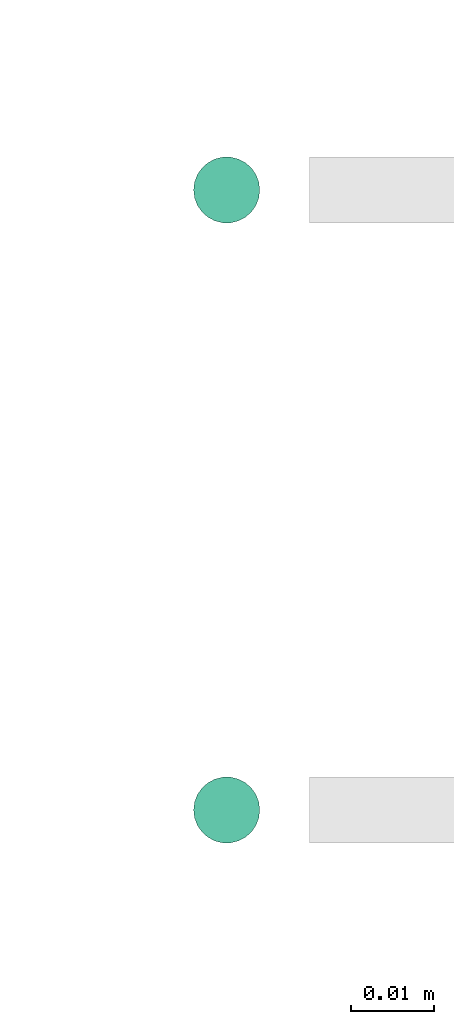
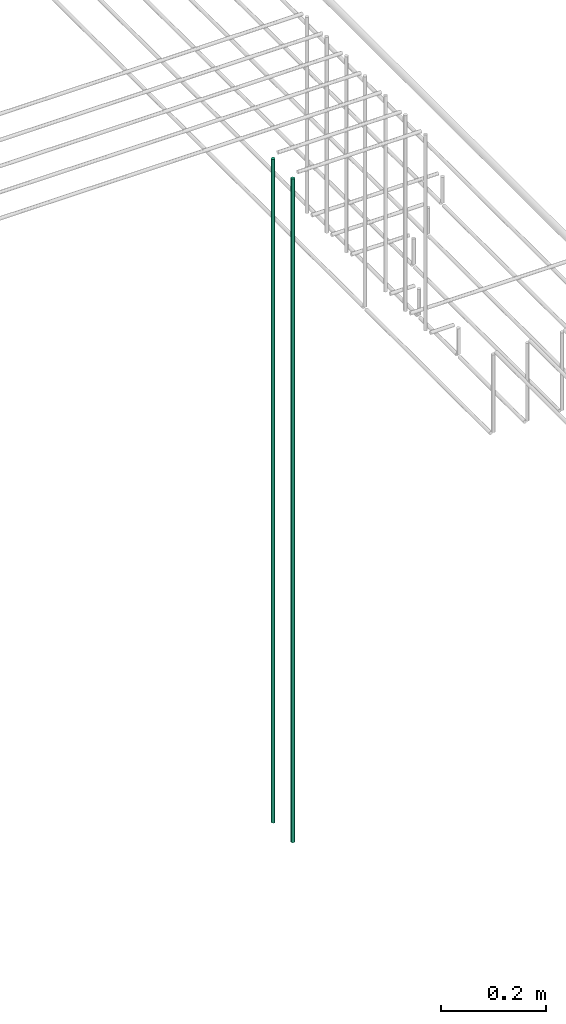
# One storey, part 19 of 89: 2 flow segments.
"""IFC2X3 building model written with IfcOpenShell, lengths in millimetres."""

from ifc_helpers import new_model, entity, si_unit, converted_unit, derived_unit, direction, frame, origin, origin_2d_with_axis, place, context, subcontext, project, spatial, circle, extrude, type_object, element, save


model = new_model("IFC2X3")

# Units and contexts
model_context = context("Model", 3, precision=0.01, world=origin(), true_north=direction((6.12303176911189e-17, 1.0)))
body_context = subcontext(model_context, "Body", "Model", "MODEL_VIEW")
ifc_project = project(units=[si_unit("LENGTHUNIT", "METRE", prefix="MILLI"), si_unit("AREAUNIT", "SQUARE_METRE"), si_unit("VOLUMEUNIT", "CUBIC_METRE"), converted_unit("PLANEANGLEUNIT", "DEGREE", entity("IfcRatioMeasure", 0.0174532925199433), si_unit("PLANEANGLEUNIT", "RADIAN"), dimensions=[0, 0, 0, 0, 0, 0, 0]), si_unit("MASSUNIT", "GRAM", prefix="KILO"), derived_unit("MASSDENSITYUNIT", [(si_unit("MASSUNIT", "GRAM", prefix="KILO"), 1), (si_unit("LENGTHUNIT", "METRE"), -3)]), derived_unit("MOMENTOFINERTIAUNIT", [(si_unit("LENGTHUNIT", "METRE"), 4)]), si_unit("TIMEUNIT", "SECOND"), si_unit("FREQUENCYUNIT", "HERTZ"), si_unit("THERMODYNAMICTEMPERATUREUNIT", "DEGREE_CELSIUS"), derived_unit("THERMALTRANSMITTANCEUNIT", [(si_unit("MASSUNIT", "GRAM", prefix="KILO"), 1), (si_unit("THERMODYNAMICTEMPERATUREUNIT", "KELVIN"), -1), (si_unit("TIMEUNIT", "SECOND"), -3)]), derived_unit("VOLUMETRICFLOWRATEUNIT", [(si_unit("LENGTHUNIT", "METRE"), 3), (si_unit("TIMEUNIT", "SECOND"), -1)]), derived_unit("MASSFLOWRATEUNIT", [(si_unit("MASSUNIT", "GRAM", prefix="KILO"), 1), (si_unit("TIMEUNIT", "SECOND"), -1)]), derived_unit("ROTATIONALFREQUENCYUNIT", [(si_unit("TIMEUNIT", "SECOND"), -1)]), si_unit("ELECTRICCURRENTUNIT", "AMPERE"), si_unit("ELECTRICVOLTAGEUNIT", "VOLT"), si_unit("POWERUNIT", "WATT"), si_unit("FORCEUNIT", "NEWTON", prefix="KILO"), si_unit("ILLUMINANCEUNIT", "LUX"), si_unit("LUMINOUSFLUXUNIT", "LUMEN"), si_unit("LUMINOUSINTENSITYUNIT", "CANDELA"), derived_unit("USERDEFINED", [(si_unit("MASSUNIT", "GRAM", prefix="KILO"), -1), (si_unit("LENGTHUNIT", "METRE"), -2), (si_unit("TIMEUNIT", "SECOND"), 3), (si_unit("LUMINOUSFLUXUNIT", "LUMEN"), 1)]), derived_unit("LINEARVELOCITYUNIT", [(si_unit("LENGTHUNIT", "METRE"), 1), (si_unit("TIMEUNIT", "SECOND"), -1)]), si_unit("PRESSUREUNIT", "PASCAL"), derived_unit("USERDEFINED", [(si_unit("LENGTHUNIT", "METRE"), -2), (si_unit("MASSUNIT", "GRAM", prefix="KILO"), 1), (si_unit("TIMEUNIT", "SECOND"), -2)]), derived_unit("LINEARFORCEUNIT", [(si_unit("MASSUNIT", "GRAM", prefix="KILO"), 1), (si_unit("LENGTHUNIT", "METRE"), 1), (si_unit("TIMEUNIT", "SECOND"), -2), (si_unit("LENGTHUNIT", "METRE"), -1)]), derived_unit("PLANARFORCEUNIT", [(si_unit("MASSUNIT", "GRAM", prefix="KILO"), 1), (si_unit("LENGTHUNIT", "METRE"), 1), (si_unit("TIMEUNIT", "SECOND"), -2), (si_unit("LENGTHUNIT", "METRE"), -2)])], contexts=[model_context])

# Site, building, storey
site_placement = place(None, frame((0.0, -0.00077364408347762, 0.0)))
site = spatial("IfcSite", under=ifc_project, at=site_placement, CompositionType="ELEMENT")
building_placement = place(site_placement, origin())
building = spatial("IfcBuilding", under=site, at=building_placement, CompositionType="ELEMENT")
storey_placement = place(building_placement, frame((0.0, 0.0, 24000.0)))
storey = spatial("IfcBuildingStorey", under=building, at=storey_placement, CompositionType="ELEMENT", Elevation=24000.0)

# Flow segments
pipe_segment_type = type_object("IfcPipeSegmentType", PredefinedType="NOTDEFINED")
for number, where in (
    (1, (66925.8680784348, 5057.64530556804, 1599.29036474498)),
    (2, (66925.8680784348, 4982.64530556804, 1599.29036474498)),
):
    element("IfcFlowSegment", number, at=place(storey_placement, frame(where)), inside=storey, type_object=pipe_segment_type, context=body_context, shape_type="SweptSolid", body=[
        extrude(circle(Radius=4.0, at=origin_2d_with_axis()), frame((5.59527223591499, 5.59527223591607, 0.0)), (0.0, 0.0, 1.0), 1540.70963525502),
    ])

save(model, "model.ifc")
